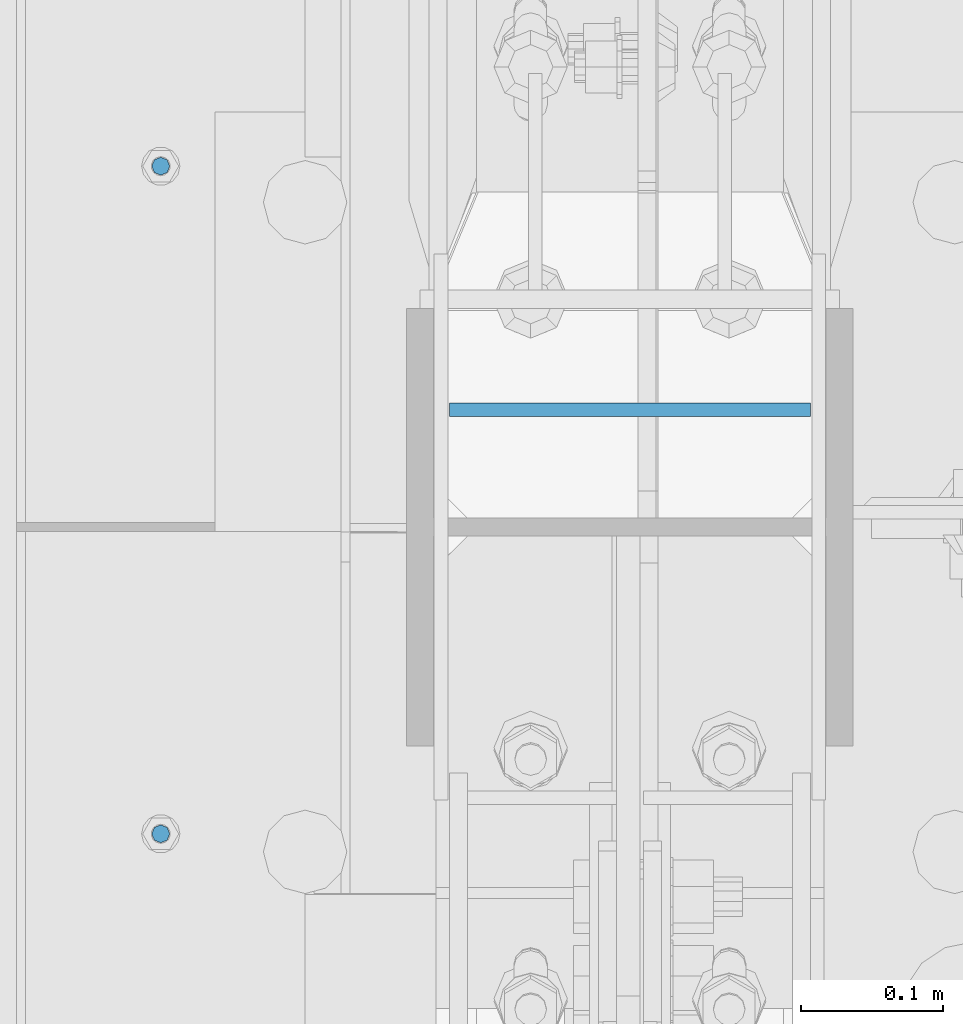
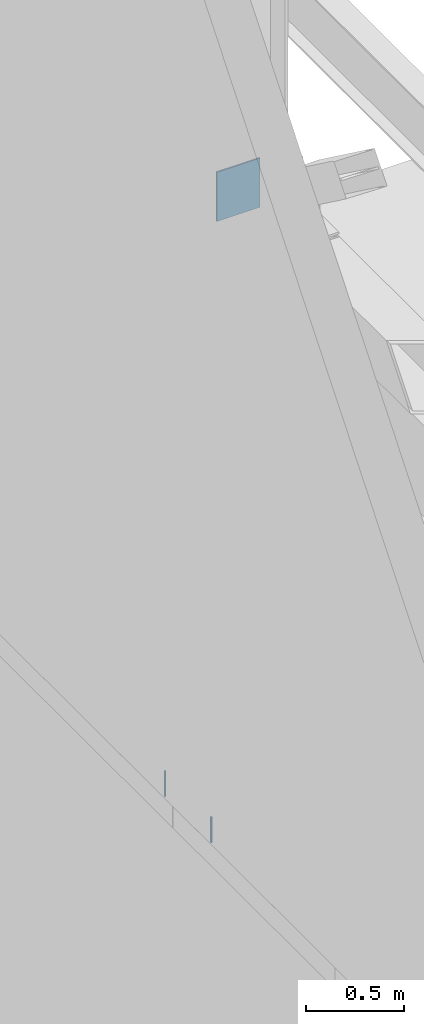
# One storey, part 419 of 1179: 3 columns, 3 elements without a shape of their own.
"""IFC2X3 building model written with IfcOpenShell, lengths in millimetres."""

from ifc_helpers import new_model, si_unit, frame, origin_with_axes, place, context, subcontext, project, spatial, faceted_brep, material, type_object, element, aggregate, save


model = new_model("IFC2X3")

# Units and contexts
model_context = context("Model", 3, precision=1e-05, world=origin_with_axes())
body_context = subcontext(model_context, "Body", "Model", "MODEL_VIEW")
ifc_project = project(units=[si_unit("LENGTHUNIT", "METRE", prefix="MILLI"), si_unit("AREAUNIT", "SQUARE_METRE"), si_unit("VOLUMEUNIT", "CUBIC_METRE"), si_unit("MASSUNIT", "GRAM", prefix="KILO"), si_unit("TIMEUNIT", "SECOND"), si_unit("PLANEANGLEUNIT", "RADIAN"), si_unit("SOLIDANGLEUNIT", "STERADIAN"), si_unit("THERMODYNAMICTEMPERATUREUNIT", "DEGREE_CELSIUS"), si_unit("LUMINOUSINTENSITYUNIT", "LUMEN")], contexts=[model_context])

# Site, building, storey
site_placement = place(None, origin_with_axes())
site = spatial("IfcSite", under=ifc_project, at=site_placement, CompositionType="ELEMENT")
building_placement = place(site_placement, origin_with_axes())
building = spatial("IfcBuilding", under=site, at=building_placement, Name="Undefined", CompositionType="ELEMENT")
storey_placement = place(building_placement, origin_with_axes())
storey = spatial("IfcBuildingStorey", under=building, at=storey_placement, Name="Undefined", CompositionType="ELEMENT", Elevation=0.0)

# Assembly, column
assembly_1_placement = place(storey_placement, origin_with_axes())
assembly_1 = element("IfcElementAssembly", 1, at=assembly_1_placement, inside=storey, Name="BEAM", AssemblyPlace="NOTDEFINED", PredefinedType="RIGID_FRAME")
ifc_material_1 = material(Name="STEEL/A307")
column_type_1 = type_object("IfcColumnType", PredefinedType="NOTDEFINED")
column_1_placement = place(assembly_1_placement, frame((101.599999999999, 19481.8, 4108.45), z_axis=(0.0, 1.0, 0.0), x_axis=(0.0, 0.0, 1.0)))
column_1 = element("IfcColumn", 2, at=column_1_placement, type_object=column_type_1, material=ifc_material_1, Name="THREADED ROD", context=body_context, shape_type="Brep", body=[
    faceted_brep([(0.0, -6.34999999999854, 0.0), (0.0, -4.49012806053361, -4.49012806053452), (157.162499999999, -4.49012806053361, -4.49012806053361), (157.162499999999, -6.34999999999854, 0.0), (0.0, 0.0, -6.34999999999991), (157.162499999999, 0.0, -6.34999999999854), (0.0, 4.49012806053361, -4.49012806053452), (157.162499999999, 4.49012806053361, -4.49012806053361), (0.0, 6.34999999999854, 0.0), (157.162499999999, 6.34999999999854, 0.0), (0.0, 4.49012806053361, 4.49012806053452), (157.162499999999, 4.49012806053361, 4.49012806053361), (0.0, 0.0, 6.34999999999991), (157.162499999999, 0.0, 6.34999999999854), (0.0, -4.49012806053361, 4.49012806053452), (157.162499999999, -4.49012806053361, 4.49012806053361)], [[[0, 1, 2, 3]], [[1, 4, 5, 2]], [[4, 6, 7, 5]], [[6, 8, 9, 7]], [[8, 10, 11, 9]], [[10, 12, 13, 11]], [[12, 14, 15, 13]], [[14, 0, 3, 15]], [[5, 7, 9, 11, 13, 15, 3, 2]], [[14, 12, 10, 8, 6, 4, 1, 0]]]),
])
aggregate(assembly_1, [column_1])

assembly_2_placement = place(storey_placement, origin_with_axes())
assembly_2 = element("IfcElementAssembly", 3, at=assembly_2_placement, inside=storey, Name="BEAM", AssemblyPlace="NOTDEFINED", PredefinedType="RIGID_FRAME")
column_2_placement = place(assembly_2_placement, frame((101.599999999999, 19011.9, 4108.45), z_axis=(0.0, 1.0, 0.0), x_axis=(0.0, 0.0, 1.0)))
column_2 = element("IfcColumn", 4, at=column_2_placement, type_object=column_type_1, material=ifc_material_1, Name="THREADED ROD", context=body_context, shape_type="Brep", body=[
    faceted_brep([(0.0, -6.34999999999854, 0.0), (0.0, -4.49012806053361, -4.49012806053452), (157.162499999999, -4.49012806053361, -4.49012806053361), (157.162499999999, -6.34999999999854, 0.0), (0.0, 0.0, -6.34999999999991), (157.162499999999, 0.0, -6.34999999999854), (0.0, 4.49012806053361, -4.49012806053452), (157.162499999999, 4.49012806053361, -4.49012806053361), (0.0, 6.34999999999854, 0.0), (157.162499999999, 6.34999999999854, 0.0), (0.0, 4.49012806053361, 4.49012806053452), (157.162499999999, 4.49012806053361, 4.49012806053361), (0.0, 0.0, 6.34999999999991), (157.162499999999, 0.0, 6.34999999999854), (0.0, -4.49012806053361, 4.49012806053452), (157.162499999999, -4.49012806053361, 4.49012806053361)], [[[0, 1, 2, 3]], [[1, 4, 5, 2]], [[4, 6, 7, 5]], [[6, 8, 9, 7]], [[8, 10, 11, 9]], [[10, 12, 13, 11]], [[12, 14, 15, 13]], [[14, 0, 3, 15]], [[5, 7, 9, 11, 13, 15, 3, 2]], [[14, 12, 10, 8, 6, 4, 1, 0]]]),
])
aggregate(assembly_2, [column_2])

assembly_3_placement = place(storey_placement, origin_with_axes())
assembly_3 = element("IfcElementAssembly", 5, at=assembly_3_placement, inside=storey, Name="BEAM", AssemblyPlace="NOTDEFINED", PredefinedType="RIGID_FRAME")
ifc_material_2 = material(Name="STEEL/A36")
column_type_2 = type_object("IfcColumnType", PredefinedType="NOTDEFINED")
column_3_placement = place(assembly_3_placement, frame((431.800000000005, 19310.35, 7708.9), z_axis=(1.0, 0.0, 0.0), x_axis=(0.0, 0.0, 1.0)))
column_3 = element("IfcColumn", 6, at=column_3_placement, type_object=column_type_2, material=ifc_material_2, Name="PLATE", context=body_context, shape_type="Brep", body=[
    faceted_brep([(0.0, 4.76249999999982, -127.0), (0.0, 4.76249999999709, 127.0), (304.799999999999, 4.76249999999982, 127.0), (304.799999999999, 4.76249999999982, -127.0), (0.0, -4.76249999999709, 127.0), (304.799999999999, -4.76249999999982, 127.0), (0.0, -4.76249999999982, -127.0), (304.799999999999, -4.76249999999982, -127.0)], [[[0, 1, 2, 3]], [[1, 4, 5, 2]], [[4, 6, 7, 5]], [[6, 0, 3, 7]], [[5, 7, 3, 2]], [[6, 4, 1, 0]]]),
])
aggregate(assembly_3, [column_3])

save(model, "model.ifc")
